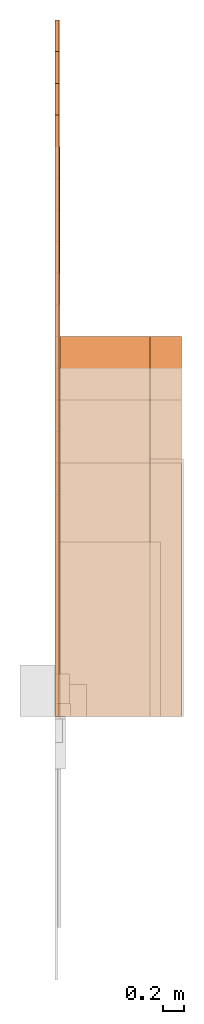
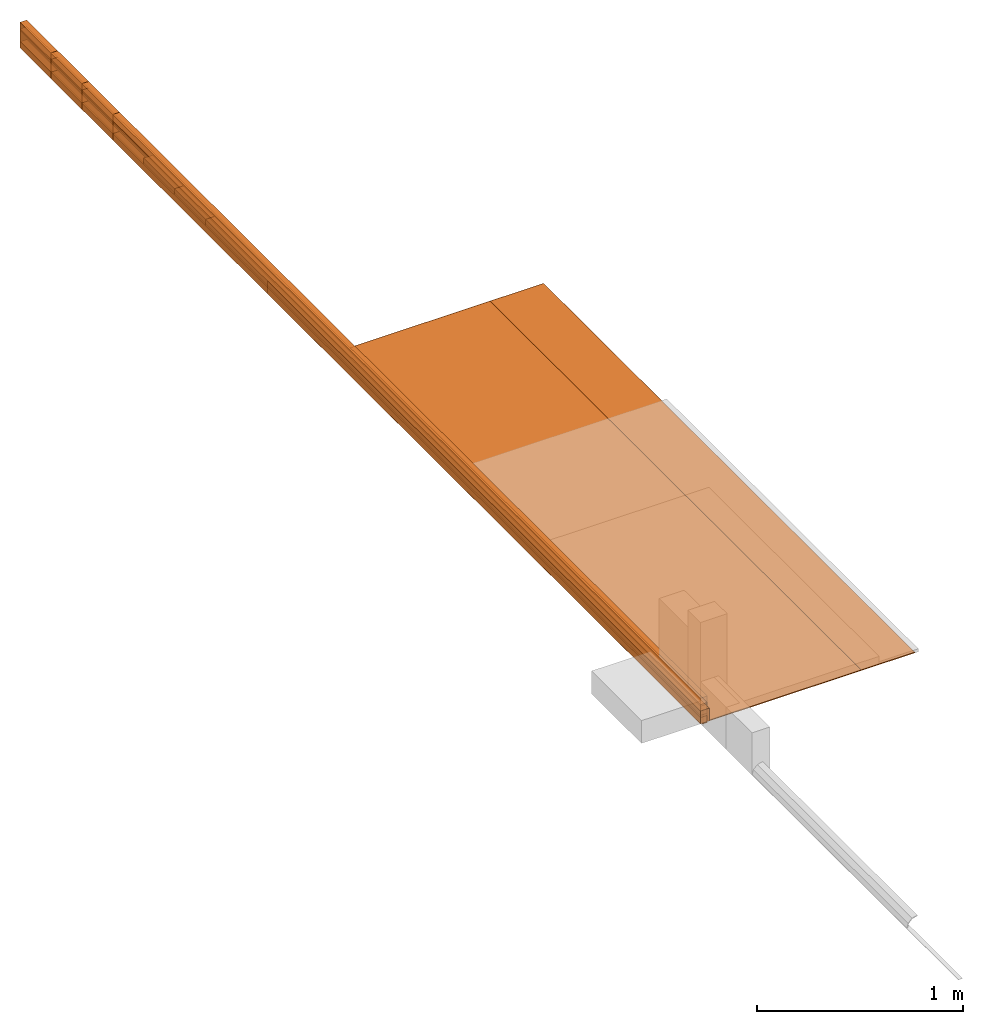
# Not in any storey, part 4 of 5: 31 proxies.
"""IFC4 model written with IfcOpenShell, lengths in metres."""

from ifc_helpers import new_model, entity, si_unit, converted_unit, direction, origin_with_axes, place, context, subcontext, project, faceted_brep, element, save


model = new_model("IFC4")

# Units and contexts
model_context = context("Model", 3, precision=1e-05, world=origin_with_axes(), true_north=direction((0.0, 1.0)))
body_context = subcontext(model_context, "Body", "Model", "MODEL_VIEW")
ifc_project = project(units=[si_unit("LENGTHUNIT", "METRE"), si_unit("AREAUNIT", "SQUARE_METRE"), si_unit("VOLUMEUNIT", "CUBIC_METRE"), converted_unit("PLANEANGLEUNIT", "DEGREE", entity("IfcPlaneAngleMeasure", 0.017453292519943295), si_unit("PLANEANGLEUNIT", "RADIAN"), dimensions=[0, 0, 0, 0, 0, 0, 0])], contexts=[model_context])

# Proxies
proxy_1_placement = place(None, origin_with_axes())
element("IfcBuildingElementProxy", 1, at=proxy_1_placement, Name="Timber 114x38x5700", context=body_context, shape_type="Brep", body=[
    faceted_brep([(0.038, 0.0, 0.0), (0.038, 0.0, 0.114), (0.0, 0.0, 0.114), (0.0, 0.0, 0.0), (0.038, 5.7, 0.0), (0.038, 5.7, 0.114), (0.038, 0.0, 0.114), (0.038, 0.0, 0.0), (0.0, 5.7, 0.0), (0.0, 5.7, 0.114), (0.038, 5.7, 0.114), (0.038, 5.7, 0.0), (0.0, 0.0, 0.0), (0.0, 0.0, 0.114), (0.0, 5.7, 0.114), (0.0, 5.7, 0.0), (0.0, 5.7, 0.0), (0.038, 5.7, 0.0), (0.038, 0.0, 0.0), (0.0, 0.0, 0.0), (0.0, 0.0, 0.114), (0.038, 0.0, 0.114), (0.038, 5.7, 0.114), (0.0, 5.7, 0.114)], [[[0, 1, 2, 3]], [[4, 5, 6, 7]], [[8, 9, 10, 11]], [[12, 13, 14, 15]], [[16, 17, 18, 19]], [[20, 21, 22, 23]]]),
])
proxy_2_placement = place(None, origin_with_axes())
element("IfcBuildingElementProxy", 2, at=proxy_2_placement, Name="Timber 114x38x6000", context=body_context, shape_type="Brep", body=[
    faceted_brep([(0.0, 6.0, 0.0), (0.0, 6.0, 0.114), (0.038, 6.0, 0.114), (0.038, 6.0, 0.0), (0.038, 6.0, 0.0), (0.038, 6.0, 0.114), (0.038, 0.0, 0.114), (0.038, 0.0, 0.0), (0.038, 0.0, 0.0), (0.038, 0.0, 0.114), (0.0, 0.0, 0.114), (0.0, 0.0, 0.0), (0.0, 0.0, 0.0), (0.0, 0.0, 0.114), (0.0, 6.0, 0.114), (0.0, 6.0, 0.0), (0.038, 0.0, 0.0), (0.0, 0.0, 0.0), (0.0, 6.0, 0.0), (0.038, 6.0, 0.0), (0.038, 6.0, 0.114), (0.0, 6.0, 0.114), (0.0, 0.0, 0.114), (0.038, 0.0, 0.114)], [[[0, 1, 2, 3]], [[4, 5, 6, 7]], [[8, 9, 10, 11]], [[12, 13, 14, 15]], [[16, 17, 18, 19]], [[20, 21, 22, 23]]]),
])
proxy_3_placement = place(None, origin_with_axes())
element("IfcBuildingElementProxy", 3, at=proxy_3_placement, Name="Timber 114x38x6300", context=body_context, shape_type="Brep", body=[
    faceted_brep([(0.038, 0.0, 0.0), (0.038, 0.0, 0.114), (0.0, 0.0, 0.114), (0.0, 0.0, 0.0), (0.038, 6.3, 0.0), (0.038, 6.3, 0.114), (0.038, 0.0, 0.114), (0.038, 0.0, 0.0), (0.0, 6.3, 0.0), (0.0, 6.3, 0.114), (0.038, 6.3, 0.114), (0.038, 6.3, 0.0), (0.0, 0.0, 0.0), (0.0, 0.0, 0.114), (0.0, 6.3, 0.114), (0.0, 6.3, 0.0), (0.0, 6.3, 0.0), (0.038, 6.3, 0.0), (0.038, 0.0, 0.0), (0.0, 0.0, 0.0), (0.0, 0.0, 0.114), (0.038, 0.0, 0.114), (0.038, 6.3, 0.114), (0.0, 6.3, 0.114)], [[[0, 1, 2, 3]], [[4, 5, 6, 7]], [[8, 9, 10, 11]], [[12, 13, 14, 15]], [[16, 17, 18, 19]], [[20, 21, 22, 23]]]),
])
proxy_4_placement = place(None, origin_with_axes())
element("IfcBuildingElementProxy", 4, at=proxy_4_placement, Name="Timber 114x38x6600", context=body_context, shape_type="Brep", body=[
    faceted_brep([(0.038, 0.0, 0.0), (0.038, 0.0, 0.114), (0.0, 0.0, 0.114), (0.0, 0.0, 0.0), (0.038, 6.6, 0.0), (0.038, 6.6, 0.114), (0.038, 0.0, 0.114), (0.038, 0.0, 0.0), (0.0, 6.6, 0.0), (0.0, 6.6, 0.114), (0.038, 6.6, 0.114), (0.038, 6.6, 0.0), (0.0, 0.0, 0.0), (0.0, 0.0, 0.114), (0.0, 6.6, 0.114), (0.0, 6.6, 0.0), (0.0, 6.6, 0.0), (0.038, 6.6, 0.0), (0.038, 0.0, 0.0), (0.0, 0.0, 0.0), (0.0, 0.0, 0.114), (0.038, 0.0, 0.114), (0.038, 6.6, 0.114), (0.0, 6.6, 0.114)], [[[0, 1, 2, 3]], [[4, 5, 6, 7]], [[8, 9, 10, 11]], [[12, 13, 14, 15]], [[16, 17, 18, 19]], [[20, 21, 22, 23]]]),
])
proxy_5_placement = place(None, origin_with_axes())
element("IfcBuildingElementProxy", 5, at=proxy_5_placement, Name="Timber 38x105x5700", context=body_context, shape_type="Brep", body=[
    faceted_brep([(0.038, 0.0, 0.0), (0.038, 0.0, 0.105), (0.0, 0.0, 0.105), (0.0, 0.0, 0.0), (0.038, 5.7, 0.0), (0.038, 5.7, 0.105), (0.038, 0.0, 0.105), (0.038, 0.0, 0.0), (0.0, 5.7, 0.0), (0.0, 5.7, 0.105), (0.038, 5.7, 0.105), (0.038, 5.7, 0.0), (0.0, 0.0, 0.0), (0.0, 0.0, 0.105), (0.0, 5.7, 0.105), (0.0, 5.7, 0.0), (0.0, 5.7, 0.0), (0.038, 5.7, 0.0), (0.038, 0.0, 0.0), (0.0, 0.0, 0.0), (0.0, 0.0, 0.105), (0.038, 0.0, 0.105), (0.038, 5.7, 0.105), (0.0, 5.7, 0.105)], [[[0, 1, 2, 3]], [[4, 5, 6, 7]], [[8, 9, 10, 11]], [[12, 13, 14, 15]], [[16, 17, 18, 19]], [[20, 21, 22, 23]]]),
])
proxy_6_placement = place(None, origin_with_axes())
element("IfcBuildingElementProxy", 6, at=proxy_6_placement, Name="Timber 38x105x6000", context=body_context, shape_type="Brep", body=[
    faceted_brep([(0.0, 6.0, 0.0), (0.0, 6.0, 0.105), (0.038, 6.0, 0.105), (0.038, 6.0, 0.0), (0.038, 6.0, 0.0), (0.038, 6.0, 0.105), (0.038, 0.0, 0.105), (0.038, 0.0, 0.0), (0.038, 0.0, 0.0), (0.038, 0.0, 0.105), (0.0, 0.0, 0.105), (0.0, 0.0, 0.0), (0.0, 0.0, 0.0), (0.0, 0.0, 0.105), (0.0, 6.0, 0.105), (0.0, 6.0, 0.0), (0.038, 0.0, 0.0), (0.0, 0.0, 0.0), (0.0, 6.0, 0.0), (0.038, 6.0, 0.0), (0.038, 6.0, 0.105), (0.0, 6.0, 0.105), (0.0, 0.0, 0.105), (0.038, 0.0, 0.105)], [[[0, 1, 2, 3]], [[4, 5, 6, 7]], [[8, 9, 10, 11]], [[12, 13, 14, 15]], [[16, 17, 18, 19]], [[20, 21, 22, 23]]]),
])
proxy_7_placement = place(None, origin_with_axes())
element("IfcBuildingElementProxy", 7, at=proxy_7_placement, Name="Timber 38x105x6300", context=body_context, shape_type="Brep", body=[
    faceted_brep([(0.038, 0.0, 0.0), (0.038, 0.0, 0.105), (0.0, 0.0, 0.105), (0.0, 0.0, 0.0), (0.038, 6.3, 0.0), (0.038, 6.3, 0.105), (0.038, 0.0, 0.105), (0.038, 0.0, 0.0), (0.0, 6.3, 0.0), (0.0, 6.3, 0.105), (0.038, 6.3, 0.105), (0.038, 6.3, 0.0), (0.0, 0.0, 0.0), (0.0, 0.0, 0.105), (0.0, 6.3, 0.105), (0.0, 6.3, 0.0), (0.0, 6.3, 0.0), (0.038, 6.3, 0.0), (0.038, 0.0, 0.0), (0.0, 0.0, 0.0), (0.0, 0.0, 0.105), (0.038, 0.0, 0.105), (0.038, 6.3, 0.105), (0.0, 6.3, 0.105)], [[[0, 1, 2, 3]], [[4, 5, 6, 7]], [[8, 9, 10, 11]], [[12, 13, 14, 15]], [[16, 17, 18, 19]], [[20, 21, 22, 23]]]),
])
proxy_8_placement = place(None, origin_with_axes())
element("IfcBuildingElementProxy", 8, at=proxy_8_placement, Name="Timber 38x105x6600", context=body_context, shape_type="Brep", body=[
    faceted_brep([(0.038, 0.0, 0.0), (0.038, 0.0, 0.105), (0.0, 0.0, 0.105), (0.0, 0.0, 0.0), (0.038, 6.6, 0.0), (0.038, 6.6, 0.105), (0.038, 0.0, 0.105), (0.038, 0.0, 0.0), (0.0, 6.6, 0.0), (0.0, 6.6, 0.105), (0.038, 6.6, 0.105), (0.038, 6.6, 0.0), (0.0, 0.0, 0.0), (0.0, 0.0, 0.105), (0.0, 6.6, 0.105), (0.0, 6.6, 0.0), (0.0, 6.6, 0.0), (0.038, 6.6, 0.0), (0.038, 0.0, 0.0), (0.0, 0.0, 0.0), (0.0, 0.0, 0.105), (0.038, 0.0, 0.105), (0.038, 6.6, 0.105), (0.0, 6.6, 0.105)], [[[0, 1, 2, 3]], [[4, 5, 6, 7]], [[8, 9, 10, 11]], [[12, 13, 14, 15]], [[16, 17, 18, 19]], [[20, 21, 22, 23]]]),
])
proxy_9_placement = place(None, origin_with_axes())
element("IfcBuildingElementProxy", 9, at=proxy_9_placement, Name="Timber 38x38x5700", context=body_context, shape_type="Brep", body=[
    faceted_brep([(0.038, 0.0, 0.0), (0.038, 0.0, 0.038), (0.0, 0.0, 0.038), (0.0, 0.0, 0.0), (0.038, 5.7, 0.0), (0.038, 5.7, 0.038), (0.038, 0.0, 0.038), (0.038, 0.0, 0.0), (0.0, 5.7, 0.0), (0.0, 5.7, 0.038), (0.038, 5.7, 0.038), (0.038, 5.7, 0.0), (0.0, 0.0, 0.0), (0.0, 0.0, 0.038), (0.0, 5.7, 0.038), (0.0, 5.7, 0.0), (0.0, 5.7, 0.0), (0.038, 5.7, 0.0), (0.038, 0.0, 0.0), (0.0, 0.0, 0.0), (0.0, 0.0, 0.038), (0.038, 0.0, 0.038), (0.038, 5.7, 0.038), (0.0, 5.7, 0.038)], [[[0, 1, 2, 3]], [[4, 5, 6, 7]], [[8, 9, 10, 11]], [[12, 13, 14, 15]], [[16, 17, 18, 19]], [[20, 21, 22, 23]]]),
])
proxy_10_placement = place(None, origin_with_axes())
element("IfcBuildingElementProxy", 10, at=proxy_10_placement, Name="Timber 38x38x6000", context=body_context, shape_type="Brep", body=[
    faceted_brep([(0.0, 6.0, 0.0), (0.0, 6.0, 0.038), (0.038, 6.0, 0.038), (0.038, 6.0, 0.0), (0.038, 6.0, 0.0), (0.038, 6.0, 0.038), (0.038, 0.0, 0.038), (0.038, 0.0, 0.0), (0.038, 0.0, 0.0), (0.038, 0.0, 0.038), (0.0, 0.0, 0.038), (0.0, 0.0, 0.0), (0.0, 0.0, 0.0), (0.0, 0.0, 0.038), (0.0, 6.0, 0.038), (0.0, 6.0, 0.0), (0.038, 0.0, 0.0), (0.0, 0.0, 0.0), (0.0, 6.0, 0.0), (0.038, 6.0, 0.0), (0.038, 6.0, 0.038), (0.0, 6.0, 0.038), (0.0, 0.0, 0.038), (0.038, 0.0, 0.038)], [[[0, 1, 2, 3]], [[4, 5, 6, 7]], [[8, 9, 10, 11]], [[12, 13, 14, 15]], [[16, 17, 18, 19]], [[20, 21, 22, 23]]]),
])
proxy_11_placement = place(None, origin_with_axes())
element("IfcBuildingElementProxy", 11, at=proxy_11_placement, Name="Timber 38x38x6300", context=body_context, shape_type="Brep", body=[
    faceted_brep([(0.038, 0.0, 0.0), (0.038, 0.0, 0.038), (0.0, 0.0, 0.038), (0.0, 0.0, 0.0), (0.038, 6.3, 0.0), (0.038, 6.3, 0.038), (0.038, 0.0, 0.038), (0.038, 0.0, 0.0), (0.0, 6.3, 0.0), (0.0, 6.3, 0.038), (0.038, 6.3, 0.038), (0.038, 6.3, 0.0), (0.0, 0.0, 0.0), (0.0, 0.0, 0.038), (0.0, 6.3, 0.038), (0.0, 6.3, 0.0), (0.0, 6.3, 0.0), (0.038, 6.3, 0.0), (0.038, 0.0, 0.0), (0.0, 0.0, 0.0), (0.0, 0.0, 0.038), (0.038, 0.0, 0.038), (0.038, 6.3, 0.038), (0.0, 6.3, 0.038)], [[[0, 1, 2, 3]], [[4, 5, 6, 7]], [[8, 9, 10, 11]], [[12, 13, 14, 15]], [[16, 17, 18, 19]], [[20, 21, 22, 23]]]),
])
proxy_12_placement = place(None, origin_with_axes())
element("IfcBuildingElementProxy", 12, at=proxy_12_placement, Name="Timber 38x38x6600", context=body_context, shape_type="Brep", body=[
    faceted_brep([(0.038, 0.0, 0.0), (0.038, 0.0, 0.038), (0.0, 0.0, 0.038), (0.0, 0.0, 0.0), (0.038, 6.6, 0.0), (0.038, 6.6, 0.038), (0.038, 0.0, 0.038), (0.038, 0.0, 0.0), (0.0, 6.6, 0.0), (0.0, 6.6, 0.038), (0.038, 6.6, 0.038), (0.038, 6.6, 0.0), (0.0, 0.0, 0.0), (0.0, 0.0, 0.038), (0.0, 6.6, 0.038), (0.0, 6.6, 0.0), (0.0, 6.6, 0.0), (0.038, 6.6, 0.0), (0.038, 0.0, 0.0), (0.0, 0.0, 0.0), (0.0, 0.0, 0.038), (0.038, 0.0, 0.038), (0.038, 6.6, 0.038), (0.0, 6.6, 0.038)], [[[0, 1, 2, 3]], [[4, 5, 6, 7]], [[8, 9, 10, 11]], [[12, 13, 14, 15]], [[16, 17, 18, 19]], [[20, 21, 22, 23]]]),
])
proxy_13_placement = place(None, origin_with_axes())
element("IfcBuildingElementProxy", 13, at=proxy_13_placement, Name="Timber 38x50x5700", context=body_context, shape_type="Brep", body=[
    faceted_brep([(0.038, 0.0, 0.0), (0.038, 0.0, 0.05), (0.0, 0.0, 0.05), (0.0, 0.0, 0.0), (0.038, 5.7, 0.0), (0.038, 5.7, 0.05), (0.038, 0.0, 0.05), (0.038, 0.0, 0.0), (0.0, 5.7, 0.0), (0.0, 5.7, 0.05), (0.038, 5.7, 0.05), (0.038, 5.7, 0.0), (0.0, 0.0, 0.0), (0.0, 0.0, 0.05), (0.0, 5.7, 0.05), (0.0, 5.7, 0.0), (0.0, 5.7, 0.0), (0.038, 5.7, 0.0), (0.038, 0.0, 0.0), (0.0, 0.0, 0.0), (0.0, 0.0, 0.05), (0.038, 0.0, 0.05), (0.038, 5.7, 0.05), (0.0, 5.7, 0.05)], [[[0, 1, 2, 3]], [[4, 5, 6, 7]], [[8, 9, 10, 11]], [[12, 13, 14, 15]], [[16, 17, 18, 19]], [[20, 21, 22, 23]]]),
])
proxy_14_placement = place(None, origin_with_axes())
element("IfcBuildingElementProxy", 14, at=proxy_14_placement, Name="Timber 38x50x6000", context=body_context, shape_type="Brep", body=[
    faceted_brep([(0.0, 6.0, 0.0), (0.0, 6.0, 0.05), (0.038, 6.0, 0.05), (0.038, 6.0, 0.0), (0.038, 6.0, 0.0), (0.038, 6.0, 0.05), (0.038, 0.0, 0.05), (0.038, 0.0, 0.0), (0.038, 0.0, 0.0), (0.038, 0.0, 0.05), (0.0, 0.0, 0.05), (0.0, 0.0, 0.0), (0.0, 0.0, 0.0), (0.0, 0.0, 0.05), (0.0, 6.0, 0.05), (0.0, 6.0, 0.0), (0.038, 0.0, 0.0), (0.0, 0.0, 0.0), (0.0, 6.0, 0.0), (0.038, 6.0, 0.0), (0.038, 6.0, 0.05), (0.0, 6.0, 0.05), (0.0, 0.0, 0.05), (0.038, 0.0, 0.05)], [[[0, 1, 2, 3]], [[4, 5, 6, 7]], [[8, 9, 10, 11]], [[12, 13, 14, 15]], [[16, 17, 18, 19]], [[20, 21, 22, 23]]]),
])
proxy_15_placement = place(None, origin_with_axes())
element("IfcBuildingElementProxy", 15, at=proxy_15_placement, Name="Timber 38x50x6300", context=body_context, shape_type="Brep", body=[
    faceted_brep([(0.038, 0.0, 0.0), (0.038, 0.0, 0.05), (0.0, 0.0, 0.05), (0.0, 0.0, 0.0), (0.038, 6.3, 0.0), (0.038, 6.3, 0.05), (0.038, 0.0, 0.05), (0.038, 0.0, 0.0), (0.0, 6.3, 0.0), (0.0, 6.3, 0.05), (0.038, 6.3, 0.05), (0.038, 6.3, 0.0), (0.0, 0.0, 0.0), (0.0, 0.0, 0.05), (0.0, 6.3, 0.05), (0.0, 6.3, 0.0), (0.0, 6.3, 0.0), (0.038, 6.3, 0.0), (0.038, 0.0, 0.0), (0.0, 0.0, 0.0), (0.0, 0.0, 0.05), (0.038, 0.0, 0.05), (0.038, 6.3, 0.05), (0.0, 6.3, 0.05)], [[[0, 1, 2, 3]], [[4, 5, 6, 7]], [[8, 9, 10, 11]], [[12, 13, 14, 15]], [[16, 17, 18, 19]], [[20, 21, 22, 23]]]),
])
proxy_16_placement = place(None, origin_with_axes())
element("IfcBuildingElementProxy", 16, at=proxy_16_placement, Name="Timber 38x50x6600", context=body_context, shape_type="Brep", body=[
    faceted_brep([(0.038, 0.0, 0.0), (0.038, 0.0, 0.038), (0.0, 0.0, 0.038), (0.0, 0.0, 0.0), (0.038, 6.6, 0.0), (0.038, 6.6, 0.038), (0.038, 0.0, 0.038), (0.038, 0.0, 0.0), (0.0, 6.6, 0.0), (0.0, 6.6, 0.038), (0.038, 6.6, 0.038), (0.038, 6.6, 0.0), (0.0, 0.0, 0.0), (0.0, 0.0, 0.038), (0.0, 6.6, 0.038), (0.0, 6.6, 0.0), (0.0, 6.6, 0.0), (0.038, 6.6, 0.0), (0.038, 0.0, 0.0), (0.0, 0.0, 0.0), (0.0, 0.0, 0.038), (0.038, 0.0, 0.038), (0.038, 6.6, 0.038), (0.0, 6.6, 0.038)], [[[0, 1, 2, 3]], [[4, 5, 6, 7]], [[8, 9, 10, 11]], [[12, 13, 14, 15]], [[16, 17, 18, 19]], [[20, 21, 22, 23]]]),
])
proxy_17_placement = place(None, origin_with_axes())
element("IfcBuildingElementProxy", 17, at=proxy_17_placement, Name="Timber 38x152x5700", context=body_context, shape_type="Brep", body=[
    faceted_brep([(0.038, 0.0, 0.0), (0.038, 0.0, 0.152), (0.0, 0.0, 0.152), (0.0, 0.0, 0.0), (0.038, 5.7, 0.0), (0.038, 5.7, 0.152), (0.038, 0.0, 0.152), (0.038, 0.0, 0.0), (0.0, 5.7, 0.0), (0.0, 5.7, 0.152), (0.038, 5.7, 0.152), (0.038, 5.7, 0.0), (0.0, 0.0, 0.0), (0.0, 0.0, 0.152), (0.0, 5.7, 0.152), (0.0, 5.7, 0.0), (0.0, 5.7, 0.0), (0.038, 5.7, 0.0), (0.038, 0.0, 0.0), (0.0, 0.0, 0.0), (0.0, 0.0, 0.152), (0.038, 0.0, 0.152), (0.038, 5.7, 0.152), (0.0, 5.7, 0.152)], [[[0, 1, 2, 3]], [[4, 5, 6, 7]], [[8, 9, 10, 11]], [[12, 13, 14, 15]], [[16, 17, 18, 19]], [[20, 21, 22, 23]]]),
])
proxy_18_placement = place(None, origin_with_axes())
element("IfcBuildingElementProxy", 18, at=proxy_18_placement, Name="Timber 38x152x6000", context=body_context, shape_type="Brep", body=[
    faceted_brep([(0.0, 6.0, 0.0), (0.0, 6.0, 0.152), (0.038, 6.0, 0.152), (0.038, 6.0, 0.0), (0.038, 6.0, 0.0), (0.038, 6.0, 0.152), (0.038, 0.0, 0.152), (0.038, 0.0, 0.0), (0.038, 0.0, 0.0), (0.038, 0.0, 0.152), (0.0, 0.0, 0.152), (0.0, 0.0, 0.0), (0.0, 0.0, 0.0), (0.0, 0.0, 0.152), (0.0, 6.0, 0.152), (0.0, 6.0, 0.0), (0.038, 0.0, 0.0), (0.0, 0.0, 0.0), (0.0, 6.0, 0.0), (0.038, 6.0, 0.0), (0.038, 6.0, 0.152), (0.0, 6.0, 0.152), (0.0, 0.0, 0.152), (0.038, 0.0, 0.152)], [[[0, 1, 2, 3]], [[4, 5, 6, 7]], [[8, 9, 10, 11]], [[12, 13, 14, 15]], [[16, 17, 18, 19]], [[20, 21, 22, 23]]]),
])
proxy_19_placement = place(None, origin_with_axes())
element("IfcBuildingElementProxy", 19, at=proxy_19_placement, Name="Timber 38x152x6300", context=body_context, shape_type="Brep", body=[
    faceted_brep([(0.038, 0.0, 0.0), (0.038, 0.0, 0.152), (0.0, 0.0, 0.152), (0.0, 0.0, 0.0), (0.038, 6.3, 0.0), (0.038, 6.3, 0.152), (0.038, 0.0, 0.152), (0.038, 0.0, 0.0), (0.0, 6.3, 0.0), (0.0, 6.3, 0.152), (0.038, 6.3, 0.152), (0.038, 6.3, 0.0), (0.0, 0.0, 0.0), (0.0, 0.0, 0.152), (0.0, 6.3, 0.152), (0.0, 6.3, 0.0), (0.0, 6.3, 0.0), (0.038, 6.3, 0.0), (0.038, 0.0, 0.0), (0.0, 0.0, 0.0), (0.0, 0.0, 0.152), (0.038, 0.0, 0.152), (0.038, 6.3, 0.152), (0.0, 6.3, 0.152)], [[[0, 1, 2, 3]], [[4, 5, 6, 7]], [[8, 9, 10, 11]], [[12, 13, 14, 15]], [[16, 17, 18, 19]], [[20, 21, 22, 23]]]),
])
proxy_20_placement = place(None, origin_with_axes())
element("IfcBuildingElementProxy", 20, at=proxy_20_placement, Name="Timber 38x152x6600", context=body_context, shape_type="Brep", body=[
    faceted_brep([(0.038, 0.0, 0.0), (0.038, 0.0, 0.152), (0.0, 0.0, 0.152), (0.0, 0.0, 0.0), (0.038, 6.6, 0.0), (0.038, 6.6, 0.152), (0.038, 0.0, 0.152), (0.038, 0.0, 0.0), (0.0, 6.6, 0.0), (0.0, 6.6, 0.152), (0.038, 6.6, 0.152), (0.038, 6.6, 0.0), (0.0, 0.0, 0.0), (0.0, 0.0, 0.152), (0.0, 6.6, 0.152), (0.0, 6.6, 0.0), (0.0, 6.6, 0.0), (0.038, 6.6, 0.0), (0.038, 0.0, 0.0), (0.0, 0.0, 0.0), (0.0, 0.0, 0.152), (0.038, 0.0, 0.152), (0.038, 6.6, 0.152), (0.0, 6.6, 0.152)], [[[0, 1, 2, 3]], [[4, 5, 6, 7]], [[8, 9, 10, 11]], [[12, 13, 14, 15]], [[16, 17, 18, 19]], [[20, 21, 22, 23]]]),
])
proxy_21_placement = place(None, origin_with_axes())
element("IfcBuildingElementProxy", 21, at=proxy_21_placement, Name="Timber 50x76x4200", context=body_context, shape_type="Brep", body=[
    faceted_brep([(0.05, 0.0, 0.0), (0.05, 0.0, 0.076), (0.0, 0.0, 0.076), (0.0, 0.0, 0.0), (0.05, 4.2, 0.0), (0.05, 4.2, 0.076), (0.05, 0.0, 0.076), (0.05, 0.0, 0.0), (0.0, 4.2, 0.0), (0.0, 4.2, 0.076), (0.05, 4.2, 0.076), (0.05, 4.2, 0.0), (0.0, 0.0, 0.0), (0.0, 0.0, 0.076), (0.0, 4.2, 0.076), (0.0, 4.2, 0.0), (0.0, 4.2, 0.0), (0.05, 4.2, 0.0), (0.05, 0.0, 0.0), (0.0, 0.0, 0.0), (0.0, 0.0, 0.076), (0.05, 0.0, 0.076), (0.05, 4.2, 0.076), (0.0, 4.2, 0.076)], [[[0, 1, 2, 3]], [[4, 5, 6, 7]], [[8, 9, 10, 11]], [[12, 13, 14, 15]], [[16, 17, 18, 19]], [[20, 21, 22, 23]]]),
])
proxy_22_placement = place(None, origin_with_axes())
element("IfcBuildingElementProxy", 22, at=proxy_22_placement, Name="Timber 50x76x4500", context=body_context, shape_type="Brep", body=[
    faceted_brep([(0.05, 0.0, 0.0), (0.05, 0.0, 0.076), (0.0, 0.0, 0.076), (0.0, 0.0, 0.0), (0.05, 4.5, 0.0), (0.05, 4.5, 0.076), (0.05, 0.0, 0.076), (0.05, 0.0, 0.0), (0.0, 4.5, 0.0), (0.0, 4.5, 0.076), (0.05, 4.5, 0.076), (0.05, 4.5, 0.0), (0.0, 0.0, 0.0), (0.0, 0.0, 0.076), (0.0, 4.5, 0.076), (0.0, 4.5, 0.0), (0.0, 4.5, 0.0), (0.05, 4.5, 0.0), (0.05, 0.0, 0.0), (0.0, 0.0, 0.0), (0.0, 0.0, 0.076), (0.05, 0.0, 0.076), (0.05, 4.5, 0.076), (0.0, 4.5, 0.076)], [[[0, 1, 2, 3]], [[4, 5, 6, 7]], [[8, 9, 10, 11]], [[12, 13, 14, 15]], [[16, 17, 18, 19]], [[20, 21, 22, 23]]]),
])
proxy_23_placement = place(None, origin_with_axes())
element("IfcBuildingElementProxy", 23, at=proxy_23_placement, Name="Timber 50x76x4800", context=body_context, shape_type="Brep", body=[
    faceted_brep([(0.05, 0.0, 0.0), (0.05, 0.0, 0.076), (0.0, 0.0, 0.076), (0.0, 0.0, 0.0), (0.05, 4.8, 0.0), (0.05, 4.8, 0.076), (0.05, 0.0, 0.076), (0.05, 0.0, 0.0), (0.0, 4.8, 0.0), (0.0, 4.8, 0.076), (0.05, 4.8, 0.076), (0.05, 4.8, 0.0), (0.0, 0.0, 0.0), (0.0, 0.0, 0.076), (0.0, 4.8, 0.076), (0.0, 4.8, 0.0), (0.0, 4.8, 0.0), (0.05, 4.8, 0.0), (0.05, 0.0, 0.0), (0.0, 0.0, 0.0), (0.0, 0.0, 0.076), (0.05, 0.0, 0.076), (0.05, 4.8, 0.076), (0.0, 4.8, 0.076)], [[[0, 1, 2, 3]], [[4, 5, 6, 7]], [[8, 9, 10, 11]], [[12, 13, 14, 15]], [[16, 17, 18, 19]], [[20, 21, 22, 23]]]),
])
proxy_24_placement = place(None, origin_with_axes())
element("IfcBuildingElementProxy", 24, at=proxy_24_placement, Name="Timber 50x76x5100", context=body_context, shape_type="Brep", body=[
    faceted_brep([(0.05, 0.0, 0.0), (0.05, 0.0, 0.076), (0.0, 0.0, 0.076), (0.0, 0.0, 0.0), (0.05, 5.1, 0.0), (0.05, 5.1, 0.076), (0.05, 0.0, 0.076), (0.05, 0.0, 0.0), (0.0, 5.1, 0.0), (0.0, 5.1, 0.076), (0.05, 5.1, 0.076), (0.05, 5.1, 0.0), (0.0, 0.0, 0.0), (0.0, 0.0, 0.076), (0.0, 5.1, 0.076), (0.0, 5.1, 0.0), (0.0, 5.1, 0.0), (0.05, 5.1, 0.0), (0.05, 0.0, 0.0), (0.0, 0.0, 0.0), (0.0, 0.0, 0.076), (0.05, 0.0, 0.076), (0.05, 5.1, 0.076), (0.0, 5.1, 0.076)], [[[0, 1, 2, 3]], [[4, 5, 6, 7]], [[8, 9, 10, 11]], [[12, 13, 14, 15]], [[16, 17, 18, 19]], [[20, 21, 22, 23]]]),
])
proxy_25_placement = place(None, origin_with_axes())
element("IfcBuildingElementProxy", 25, at=proxy_25_placement, Name="Timber 50x76x5400", context=body_context, shape_type="Brep", body=[
    faceted_brep([(0.05, 0.0, 0.0), (0.05, 0.0, 0.076), (0.0, 0.0, 0.076), (0.0, 0.0, 0.0), (0.05, 5.4, 0.0), (0.05, 5.4, 0.076), (0.05, 0.0, 0.076), (0.05, 0.0, 0.0), (0.0, 5.4, 0.0), (0.0, 5.4, 0.076), (0.05, 5.4, 0.076), (0.05, 5.4, 0.0), (0.0, 0.0, 0.0), (0.0, 0.0, 0.076), (0.0, 5.4, 0.076), (0.0, 5.4, 0.0), (0.0, 5.4, 0.0), (0.05, 5.4, 0.0), (0.05, 0.0, 0.0), (0.0, 0.0, 0.0), (0.0, 0.0, 0.076), (0.05, 0.0, 0.076), (0.05, 5.4, 0.076), (0.0, 5.4, 0.076)], [[[0, 1, 2, 3]], [[4, 5, 6, 7]], [[8, 9, 10, 11]], [[12, 13, 14, 15]], [[16, 17, 18, 19]], [[20, 21, 22, 23]]]),
])
proxy_26_placement = place(None, origin_with_axes())
element("IfcBuildingElementProxy", 26, at=proxy_26_placement, Name="900x3600x4", context=body_context, shape_type="Brep", body=[
    faceted_brep([(0.9, 0.0, 0.0), (0.9, 0.0, 0.004), (0.0, 0.0, 0.004), (0.0, 0.0, 0.0), (0.9, 3.6, 0.0), (0.9, 3.6, 0.004), (0.9, 0.0, 0.004), (0.9, 0.0, 0.0), (0.0, 3.6, 0.0), (0.0, 3.6, 0.004), (0.9, 3.6, 0.004), (0.9, 3.6, 0.0), (0.0, 0.0, 0.0), (0.0, 0.0, 0.004), (0.0, 3.6, 0.004), (0.0, 3.6, 0.0), (0.0, 3.6, 0.0), (0.9, 3.6, 0.0), (0.9, 0.0, 0.0), (0.0, 0.0, 0.0), (0.0, 0.0, 0.004), (0.9, 0.0, 0.004), (0.9, 3.6, 0.004), (0.0, 3.6, 0.004)], [[[0, 1, 2, 3]], [[4, 5, 6, 7]], [[8, 9, 10, 11]], [[12, 13, 14, 15]], [[16, 17, 18, 19]], [[20, 21, 22, 23]]]),
])
proxy_27_placement = place(None, origin_with_axes())
element("IfcBuildingElementProxy", 27, at=proxy_27_placement, Name="1200x3600x4", context=body_context, shape_type="Brep", body=[
    faceted_brep([(1.2, 0.0, 0.0), (1.2, 0.0, 0.004), (0.0, 0.0, 0.004), (0.0, 0.0, 0.0), (1.2, 3.6, 0.0), (1.2, 3.6, 0.004), (1.2, 0.0, 0.004), (1.2, 0.0, 0.0), (0.0, 3.6, 0.0), (0.0, 3.6, 0.004), (1.2, 3.6, 0.004), (1.2, 3.6, 0.0), (0.0, 0.0, 0.0), (0.0, 0.0, 0.004), (0.0, 3.6, 0.004), (0.0, 3.6, 0.0), (0.0, 3.6, 0.0), (1.2, 3.6, 0.0), (1.2, 0.0, 0.0), (0.0, 0.0, 0.0), (0.0, 0.0, 0.004), (1.2, 0.0, 0.004), (1.2, 3.6, 0.004), (0.0, 3.6, 0.004)], [[[0, 1, 2, 3]], [[4, 5, 6, 7]], [[8, 9, 10, 11]], [[12, 13, 14, 15]], [[16, 17, 18, 19]], [[20, 21, 22, 23]]]),
])
proxy_28_placement = place(None, origin_with_axes())
element("IfcBuildingElementProxy", 28, at=proxy_28_placement, Name="900x3600x6", context=body_context, shape_type="Brep", body=[
    faceted_brep([(0.9, 0.0, 0.0), (0.9, 0.0, 0.006), (0.0, 0.0, 0.006), (0.0, 0.0, 0.0), (0.9, 3.6, 0.0), (0.9, 3.6, 0.006), (0.9, 0.0, 0.006), (0.9, 0.0, 0.0), (0.0, 3.6, 0.0), (0.0, 3.6, 0.006), (0.9, 3.6, 0.006), (0.9, 3.6, 0.0), (0.0, 0.0, 0.0), (0.0, 0.0, 0.006), (0.0, 3.6, 0.006), (0.0, 3.6, 0.0), (0.0, 3.6, 0.0), (0.9, 3.6, 0.0), (0.9, 0.0, 0.0), (0.0, 0.0, 0.0), (0.0, 0.0, 0.006), (0.9, 0.0, 0.006), (0.9, 3.6, 0.006), (0.0, 3.6, 0.006)], [[[0, 1, 2, 3]], [[4, 5, 6, 7]], [[8, 9, 10, 11]], [[12, 13, 14, 15]], [[16, 17, 18, 19]], [[20, 21, 22, 23]]]),
])
proxy_29_placement = place(None, origin_with_axes())
element("IfcBuildingElementProxy", 29, at=proxy_29_placement, Name="1200x3600x6", context=body_context, shape_type="Brep", body=[
    faceted_brep([(1.2, 0.0, 0.0), (1.2, 0.0, 0.006), (0.0, 0.0, 0.006), (0.0, 0.0, 0.0), (1.2, 3.6, 0.0), (1.2, 3.6, 0.006), (1.2, 0.0, 0.006), (1.2, 0.0, 0.0), (0.0, 3.6, 0.0), (0.0, 3.6, 0.006), (1.2, 3.6, 0.006), (1.2, 3.6, 0.0), (0.0, 0.0, 0.0), (0.0, 0.0, 0.006), (0.0, 3.6, 0.006), (0.0, 3.6, 0.0), (0.0, 3.6, 0.0), (1.2, 3.6, 0.0), (1.2, 0.0, 0.0), (0.0, 0.0, 0.0), (0.0, 0.0, 0.006), (1.2, 0.0, 0.006), (1.2, 3.6, 0.006), (0.0, 3.6, 0.006)], [[[0, 1, 2, 3]], [[4, 5, 6, 7]], [[8, 9, 10, 11]], [[12, 13, 14, 15]], [[16, 17, 18, 19]], [[20, 21, 22, 23]]]),
])
proxy_30_placement = place(None, origin_with_axes())
element("IfcBuildingElementProxy", 30, at=proxy_30_placement, Name="Strip 4x3600", context=body_context, shape_type="Brep", body=[
    faceted_brep([(0.025, 0.0, 0.0), (0.025, 3.6, 7.99360577730113e-16), (0.0, 3.6, 7.99360577730113e-16), (0.0, 0.0, 0.0), (0.025, 1.02140518265514e-18, -0.0046), (0.025, 3.6, -0.0045999999999992), (0.025, 3.6, 7.99360577730113e-16), (0.025, 0.0, 0.0), (0.01055, 1.02140518265514e-18, -0.0046), (0.01055, 3.6, -0.0045999999999992), (0.025, 3.6, -0.0045999999999992), (0.025, 1.02140518265514e-18, -0.0046), (0.01055, 1.13242748511766e-18, -0.0051), (0.01055, 3.6, -0.0050999999999992), (0.01055, 3.6, -0.0045999999999992), (0.01055, 1.02140518265514e-18, -0.0046), (0.03995, 1.13242748511766e-18, -0.0051), (0.03995, 3.6, -0.0050999999999992), (0.01055, 3.6, -0.0050999999999992), (0.01055, 1.13242748511766e-18, -0.0051), (0.03995, 1.02140518265514e-18, -0.0046), (0.03995, 3.6, -0.0045999999999992), (0.03995, 3.6, -0.0050999999999992), (0.03995, 1.13242748511766e-18, -0.0051), (0.0255, 1.02140518265514e-18, -0.0046), (0.0255, 3.6, -0.0045999999999992), (0.03995, 3.6, -0.0045999999999992), (0.03995, 1.02140518265514e-18, -0.0046), (0.0255, 0.0, 0.0), (0.0255, 3.6, 7.99360577730113e-16), (0.0255, 3.6, -0.0045999999999992), (0.0255, 1.02140518265514e-18, -0.0046), (0.0505, 0.0, 0.0), (0.0505, 3.6, 7.99360577730113e-16), (0.0255, 3.6, 7.99360577730113e-16), (0.0255, 0.0, 0.0), (0.0505, 6.66133814775094e-20, -0.0003), (0.0505, 3.6, -0.000299999999999201), (0.0505, 3.6, 7.99360577730113e-16), (0.0505, 0.0, 0.0), (0.0258, 6.66133814775094e-20, -0.0003), (0.0258, 3.6, -0.000299999999999201), (0.0505, 3.6, -0.000299999999999201), (0.0505, 6.66133814775094e-20, -0.0003), (0.0258, 9.54791801177635e-19, -0.0043), (0.0258, 3.6, -0.0042999999999992), (0.0258, 3.6, -0.000299999999999201), (0.0258, 6.66133814775094e-20, -0.0003), (0.04025, 9.54791801177635e-19, -0.0043), (0.04025, 3.6, -0.0042999999999992), (0.0258, 3.6, -0.0042999999999992), (0.0258, 9.54791801177635e-19, -0.0043), (0.04025, 1.19904086659517e-18, -0.0054), (0.04025, 3.6, -0.0053999999999992), (0.04025, 3.6, -0.0042999999999992), (0.04025, 9.54791801177635e-19, -0.0043), (0.01025, 1.19904086659517e-18, -0.0054), (0.01025, 3.6, -0.0053999999999992), (0.04025, 3.6, -0.0053999999999992), (0.04025, 1.19904086659517e-18, -0.0054), (0.01025, 9.54791801177635e-19, -0.0043), (0.01025, 3.6, -0.0042999999999992), (0.01025, 3.6, -0.0053999999999992), (0.01025, 1.19904086659517e-18, -0.0054), (0.0247, 9.54791801177635e-19, -0.0043), (0.0247, 3.6, -0.0042999999999992), (0.01025, 3.6, -0.0042999999999992), (0.01025, 9.54791801177635e-19, -0.0043), (0.0247, 6.66133814775094e-20, -0.0003), (0.0247, 3.6, -0.000299999999999201), (0.0247, 3.6, -0.0042999999999992), (0.0247, 9.54791801177635e-19, -0.0043), (0.0, 6.66133814775094e-20, -0.0003), (0.0, 3.6, -0.000299999999999201), (0.0247, 3.6, -0.000299999999999201), (0.0247, 6.66133814775094e-20, -0.0003), (0.0, 0.0, 0.0), (0.0, 3.6, 7.99360577730113e-16), (0.0, 3.6, -0.000299999999999201), (0.0, 6.66133814775094e-20, -0.0003), (0.0, 6.66133814775094e-20, -0.0003), (0.0247, 6.66133814775094e-20, -0.0003), (0.0247, 9.54791801177635e-19, -0.0043), (0.01025, 9.54791801177635e-19, -0.0043), (0.01025, 1.19904086659517e-18, -0.0054), (0.04025, 1.19904086659517e-18, -0.0054), (0.04025, 9.54791801177635e-19, -0.0043), (0.0258, 9.54791801177635e-19, -0.0043), (0.0258, 6.66133814775094e-20, -0.0003), (0.0505, 6.66133814775094e-20, -0.0003), (0.0505, 0.0, 0.0), (0.0255, 0.0, 0.0), (0.0255, 1.02140518265514e-18, -0.0046), (0.03995, 1.02140518265514e-18, -0.0046), (0.03995, 1.13242748511766e-18, -0.0051), (0.01055, 1.13242748511766e-18, -0.0051), (0.01055, 1.02140518265514e-18, -0.0046), (0.025, 1.02140518265514e-18, -0.0046), (0.025, 0.0, 0.0), (0.0, 0.0, 0.0), (0.0, 3.6, 7.99360577730113e-16), (0.025, 3.6, 7.99360577730113e-16), (0.025, 3.6, -0.0045999999999992), (0.01055, 3.6, -0.0045999999999992), (0.01055, 3.6, -0.0050999999999992), (0.03995, 3.6, -0.0050999999999992), (0.03995, 3.6, -0.0045999999999992), (0.0255, 3.6, -0.0045999999999992), (0.0255, 3.6, 7.99360577730113e-16), (0.0505, 3.6, 7.99360577730113e-16), (0.0505, 3.6, -0.000299999999999201), (0.0258, 3.6, -0.000299999999999201), (0.0258, 3.6, -0.0042999999999992), (0.04025, 3.6, -0.0042999999999992), (0.04025, 3.6, -0.0053999999999992), (0.01025, 3.6, -0.0053999999999992), (0.01025, 3.6, -0.0042999999999992), (0.0247, 3.6, -0.0042999999999992), (0.0247, 3.6, -0.000299999999999201), (0.0, 3.6, -0.000299999999999201)], [[[0, 1, 2, 3]], [[4, 5, 6, 7]], [[8, 9, 10, 11]], [[12, 13, 14, 15]], [[16, 17, 18, 19]], [[20, 21, 22, 23]], [[24, 25, 26, 27]], [[28, 29, 30, 31]], [[32, 33, 34, 35]], [[36, 37, 38, 39]], [[40, 41, 42, 43]], [[44, 45, 46, 47]], [[48, 49, 50, 51]], [[52, 53, 54, 55]], [[56, 57, 58, 59]], [[60, 61, 62, 63]], [[64, 65, 66, 67]], [[68, 69, 70, 71]], [[72, 73, 74, 75]], [[76, 77, 78, 79]], [[80, 81, 82, 83, 84, 85, 86, 87, 88, 89, 90, 91, 92, 93, 94, 95, 96, 97, 98, 99]], [[100, 101, 102, 103, 104, 105, 106, 107, 108, 109, 110, 111, 112, 113, 114, 115, 116, 117, 118, 119]]]),
])
proxy_31_placement = place(None, origin_with_axes())
element("IfcBuildingElementProxy", 31, at=proxy_31_placement, Name="Strip 4x4200", context=body_context, shape_type="Brep", body=[
    faceted_brep([(0.025, 0.0, 0.0), (0.025, 4.2, 9.32587340685132e-16), (0.0, 4.2, 9.32587340685132e-16), (0.0, 0.0, 0.0), (0.025, 1.02140518265514e-18, -0.0046), (0.025, 4.2, -0.00459999999999907), (0.025, 4.2, 9.32587340685132e-16), (0.025, 0.0, 0.0), (0.01055, 1.02140518265514e-18, -0.0046), (0.01055, 4.2, -0.00459999999999907), (0.025, 4.2, -0.00459999999999907), (0.025, 1.02140518265514e-18, -0.0046), (0.01055, 1.13242748511766e-18, -0.0051), (0.01055, 4.2, -0.00509999999999907), (0.01055, 4.2, -0.00459999999999907), (0.01055, 1.02140518265514e-18, -0.0046), (0.03995, 1.13242748511766e-18, -0.0051), (0.03995, 4.2, -0.00509999999999907), (0.01055, 4.2, -0.00509999999999907), (0.01055, 1.13242748511766e-18, -0.0051), (0.03995, 1.02140518265514e-18, -0.0046), (0.03995, 4.2, -0.00459999999999907), (0.03995, 4.2, -0.00509999999999907), (0.03995, 1.13242748511766e-18, -0.0051), (0.0255, 1.02140518265514e-18, -0.0046), (0.0255, 4.2, -0.00459999999999907), (0.03995, 4.2, -0.00459999999999907), (0.03995, 1.02140518265514e-18, -0.0046), (0.0255, 0.0, 0.0), (0.0255, 4.2, 9.32587340685132e-16), (0.0255, 4.2, -0.00459999999999907), (0.0255, 1.02140518265514e-18, -0.0046), (0.0505, 0.0, 0.0), (0.0505, 4.2, 9.32587340685132e-16), (0.0255, 4.2, 9.32587340685132e-16), (0.0255, 0.0, 0.0), (0.0505, 6.66133814775094e-20, -0.0003), (0.0505, 4.2, -0.000299999999999067), (0.0505, 4.2, 9.32587340685132e-16), (0.0505, 0.0, 0.0), (0.0258, 6.66133814775094e-20, -0.0003), (0.0258, 4.2, -0.000299999999999067), (0.0505, 4.2, -0.000299999999999067), (0.0505, 6.66133814775094e-20, -0.0003), (0.0258, 9.54791801177635e-19, -0.0043), (0.0258, 4.2, -0.00429999999999907), (0.0258, 4.2, -0.000299999999999067), (0.0258, 6.66133814775094e-20, -0.0003), (0.04025, 9.54791801177635e-19, -0.0043), (0.04025, 4.2, -0.00429999999999907), (0.0258, 4.2, -0.00429999999999907), (0.0258, 9.54791801177635e-19, -0.0043), (0.04025, 1.19904086659517e-18, -0.0054), (0.04025, 4.2, -0.00539999999999907), (0.04025, 4.2, -0.00429999999999907), (0.04025, 9.54791801177635e-19, -0.0043), (0.01025, 1.19904086659517e-18, -0.0054), (0.01025, 4.2, -0.00539999999999907), (0.04025, 4.2, -0.00539999999999907), (0.04025, 1.19904086659517e-18, -0.0054), (0.01025, 9.54791801177635e-19, -0.0043), (0.01025, 4.2, -0.00429999999999907), (0.01025, 4.2, -0.00539999999999907), (0.01025, 1.19904086659517e-18, -0.0054), (0.0247, 9.54791801177635e-19, -0.0043), (0.0247, 4.2, -0.00429999999999907), (0.01025, 4.2, -0.00429999999999907), (0.01025, 9.54791801177635e-19, -0.0043), (0.0247, 6.66133814775094e-20, -0.0003), (0.0247, 4.2, -0.000299999999999067), (0.0247, 4.2, -0.00429999999999907), (0.0247, 9.54791801177635e-19, -0.0043), (0.0, 6.66133814775094e-20, -0.0003), (0.0, 4.2, -0.000299999999999067), (0.0247, 4.2, -0.000299999999999067), (0.0247, 6.66133814775094e-20, -0.0003), (0.0, 0.0, 0.0), (0.0, 4.2, 9.32587340685132e-16), (0.0, 4.2, -0.000299999999999067), (0.0, 6.66133814775094e-20, -0.0003), (0.0, 6.66133814775094e-20, -0.0003), (0.0247, 6.66133814775094e-20, -0.0003), (0.0247, 9.54791801177635e-19, -0.0043), (0.01025, 9.54791801177635e-19, -0.0043), (0.01025, 1.19904086659517e-18, -0.0054), (0.04025, 1.19904086659517e-18, -0.0054), (0.04025, 9.54791801177635e-19, -0.0043), (0.0258, 9.54791801177635e-19, -0.0043), (0.0258, 6.66133814775094e-20, -0.0003), (0.0505, 6.66133814775094e-20, -0.0003), (0.0505, 0.0, 0.0), (0.0255, 0.0, 0.0), (0.0255, 1.02140518265514e-18, -0.0046), (0.03995, 1.02140518265514e-18, -0.0046), (0.03995, 1.13242748511766e-18, -0.0051), (0.01055, 1.13242748511766e-18, -0.0051), (0.01055, 1.02140518265514e-18, -0.0046), (0.025, 1.02140518265514e-18, -0.0046), (0.025, 0.0, 0.0), (0.0, 0.0, 0.0), (0.0, 4.2, 9.32587340685132e-16), (0.025, 4.2, 9.32587340685132e-16), (0.025, 4.2, -0.00459999999999907), (0.01055, 4.2, -0.00459999999999907), (0.01055, 4.2, -0.00509999999999907), (0.03995, 4.2, -0.00509999999999907), (0.03995, 4.2, -0.00459999999999907), (0.0255, 4.2, -0.00459999999999907), (0.0255, 4.2, 9.32587340685132e-16), (0.0505, 4.2, 9.32587340685132e-16), (0.0505, 4.2, -0.000299999999999067), (0.0258, 4.2, -0.000299999999999067), (0.0258, 4.2, -0.00429999999999907), (0.04025, 4.2, -0.00429999999999907), (0.04025, 4.2, -0.00539999999999907), (0.01025, 4.2, -0.00539999999999907), (0.01025, 4.2, -0.00429999999999907), (0.0247, 4.2, -0.00429999999999907), (0.0247, 4.2, -0.000299999999999067), (0.0, 4.2, -0.000299999999999067)], [[[0, 1, 2, 3]], [[4, 5, 6, 7]], [[8, 9, 10, 11]], [[12, 13, 14, 15]], [[16, 17, 18, 19]], [[20, 21, 22, 23]], [[24, 25, 26, 27]], [[28, 29, 30, 31]], [[32, 33, 34, 35]], [[36, 37, 38, 39]], [[40, 41, 42, 43]], [[44, 45, 46, 47]], [[48, 49, 50, 51]], [[52, 53, 54, 55]], [[56, 57, 58, 59]], [[60, 61, 62, 63]], [[64, 65, 66, 67]], [[68, 69, 70, 71]], [[72, 73, 74, 75]], [[76, 77, 78, 79]], [[80, 81, 82, 83, 84, 85, 86, 87, 88, 89, 90, 91, 92, 93, 94, 95, 96, 97, 98, 99]], [[100, 101, 102, 103, 104, 105, 106, 107, 108, 109, 110, 111, 112, 113, 114, 115, 116, 117, 118, 119]]]),
])

save(model, "model.ifc")
